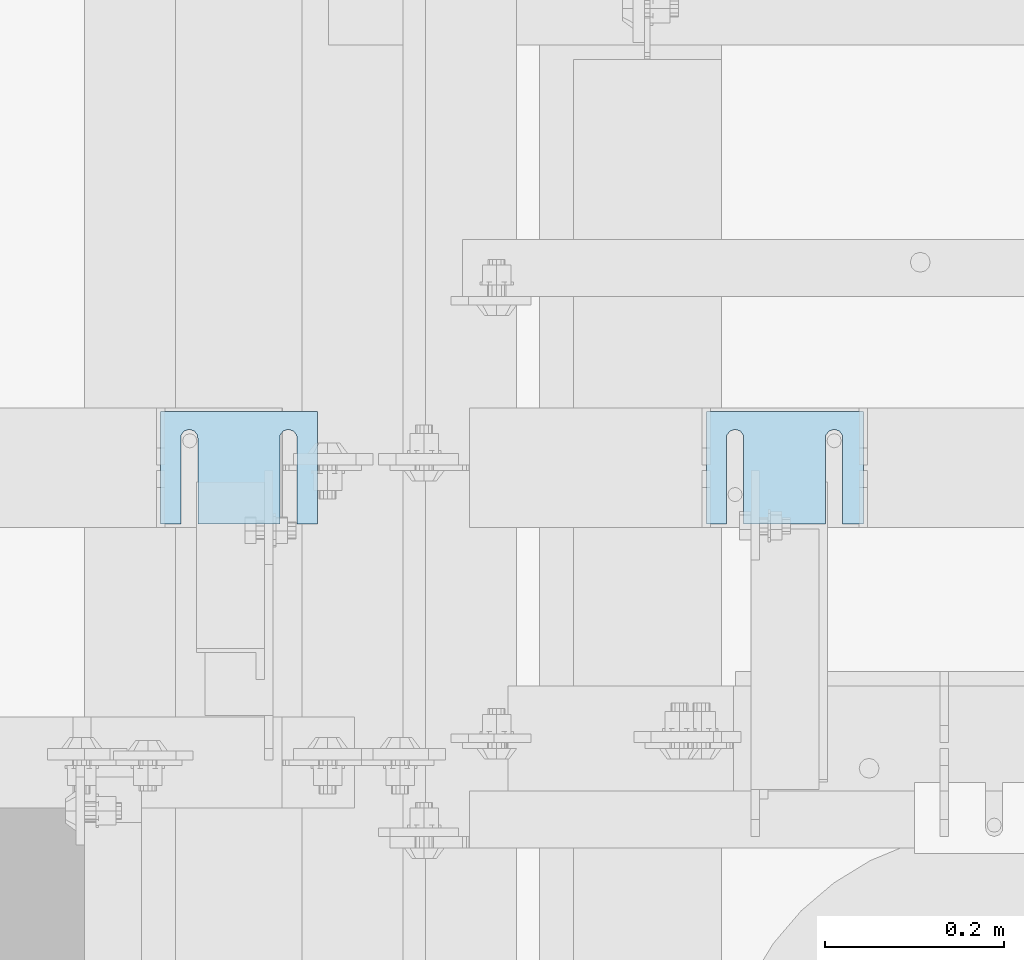
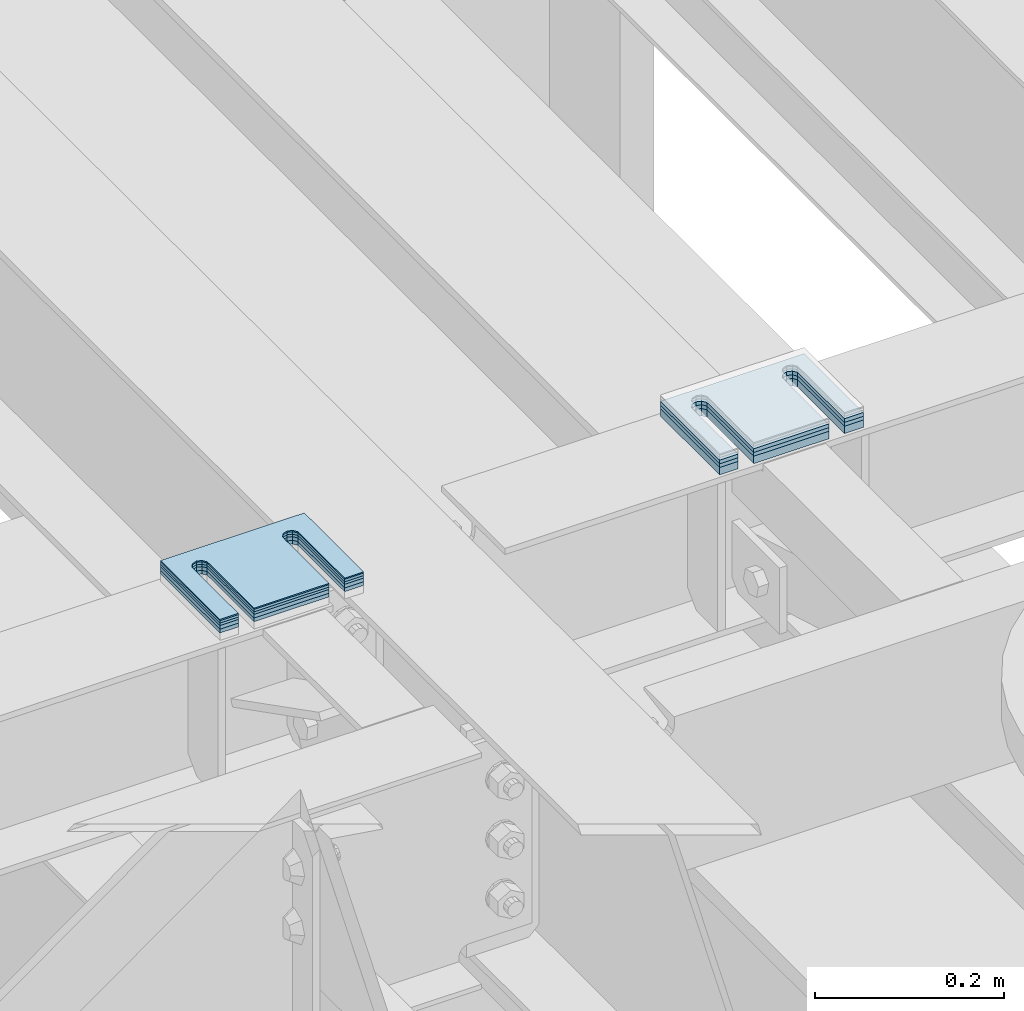
# One storey, part 1611 of 1876: 8 plates, 8 elements without a shape of their own.
"""IFC2X3 building model written with IfcOpenShell, lengths in millimetres."""

import ifcopenshell
import ifcopenshell.guid

model = None  # the IFC model being written
_history = None  # IfcOwnerHistory: only IFC2X3 demands one
_inside = {}  # id of a spatial element -> (the spatial element, [elements in it])
_under = {}  # id of a project, library or spatial element -> (it, [spatial elements below it])
_declared = {}  # id of a project -> (the project, [libraries it declares])
_typed = {}  # id of a type object -> (the type object, [elements of that type])
_made_of = {}  # id of a material, layer set ... -> (it, [elements and type objects made of it])


def new_model(schema):
    """Start an empty IFC model of exactly this schema.

    Asked for "IFC4X3", IfcOpenShell would pick the latest addendum, in which some entities
    have other attributes; the version numbers below select the first issue.
    IFC2X3 requires an IfcOwnerHistory on every rooted entity: one is made here for all.
    """
    global model, _history
    if schema == "IFC4X3":
        model = ifcopenshell.file(schema_version=(4, 3, 0, 0))
    else:
        model = ifcopenshell.file(schema=schema)
    _inside.clear()
    _under.clear()
    _declared.clear()
    _typed.clear()
    _made_of.clear()
    _history = None
    if model.schema == "IFC2X3":
        org = make("IfcOrganization", Name="unknown")
        user = make(
            "IfcPersonAndOrganization",
            ThePerson=make("IfcPerson", FamilyName="unknown"),
            TheOrganization=org,
        )
        app = make(
            "IfcApplication",
            ApplicationDeveloper=org,
            Version="unknown",
            ApplicationFullName="unknown",
            ApplicationIdentifier="unknown",
        )
        _history = make(
            "IfcOwnerHistory",
            OwningUser=user,
            OwningApplication=app,
            ChangeAction="ADDED",
            CreationDate=0,
        )
    return model


def make(cls, **values):
    """One entity of the class cls with the attributes given. An attribute that is None is left unset."""
    return model.create_entity(
        cls, **{name: value for name, value in values.items() if value is not None}
    )


def rooted(cls, **values):
    """An entity with a GlobalId (a new one), such as an element, a storey or a relation."""
    return make(cls, GlobalId=ifcopenshell.guid.new(), OwnerHistory=_history, **values)


def si_unit(unit_type, name, prefix=None):
    """IfcSIUnit, for example si_unit("LENGTHUNIT", "METRE", prefix="MILLI")."""
    return make("IfcSIUnit", UnitType=unit_type, Prefix=prefix, Name=name)


def assignment(units):
    """IfcUnitAssignment: the units of a project."""
    return None if units is None else make("IfcUnitAssignment", Units=units)


def point(xyz):
    """IfcCartesianPoint."""
    return None if xyz is None else make("IfcCartesianPoint", Coordinates=xyz)


def direction(xyz):
    """IfcDirection."""
    return None if xyz is None else make("IfcDirection", DirectionRatios=xyz)


def frame(location, z_axis=None, x_axis=None):
    """IfcAxis2Placement3D, a coordinate frame: its origin and axes. An axis left out is left unset."""
    return make(
        "IfcAxis2Placement3D",
        Location=point(location),
        Axis=direction(z_axis),
        RefDirection=direction(x_axis),
    )


def origin_with_axes():
    """The frame at (0, 0, 0) with the z axis (0, 0, 1) and the x axis (1, 0, 0) written out."""
    return frame((0.0, 0.0, 0.0), z_axis=(0.0, 0.0, 1.0), x_axis=(1.0, 0.0, 0.0))


def place(relative_to, where):
    """IfcLocalPlacement: puts the frame where relative to a parent placement (None: the world)."""
    return make(
        "IfcLocalPlacement", PlacementRelTo=relative_to, RelativePlacement=where
    )


def context(
    kind, dimensions, precision=None, world=None, true_north=None, identifier=None
):
    """IfcGeometricRepresentationContext, for example the 3D "Model" context."""
    return make(
        "IfcGeometricRepresentationContext",
        ContextIdentifier=identifier,
        ContextType=kind,
        CoordinateSpaceDimension=dimensions,
        Precision=precision,
        WorldCoordinateSystem=world,
        TrueNorth=true_north,
    )


def subcontext(parent, identifier, kind, view, scale=None):
    """IfcGeometricRepresentationSubContext, for example "Body" below "Model"."""
    return make(
        "IfcGeometricRepresentationSubContext",
        ContextIdentifier=identifier,
        ContextType=kind,
        ParentContext=parent,
        TargetScale=scale,
        TargetView=view,
    )


def project(units=None, contexts=None):
    """IfcProject with its units and contexts."""
    return rooted(
        "IfcProject",
        Name="project",
        RepresentationContexts=contexts,
        UnitsInContext=assignment(units),
    )


def spatial(cls, under=None, at=None, **own):
    """A site, building, storey or space (cls), placed at a placement, below another one or the project."""
    s = rooted(cls, ObjectPlacement=at, **own)
    if under is not None:
        _under.setdefault(under.id(), (under, []))[1].append(s)
    return s


def faces_of(points, faces, orient=None, outer=None):
    """IfcFace entities. A face is a list of loops; a loop is a list of indices into points, from 0.

    orient and outer hold one flag for each loop. By default every Orientation is true, the
    first loop of a face is its IfcFaceOuterBound and the others are IfcFaceBound.
    """
    made = []
    for i, loops in enumerate(faces):
        bounds = []
        for j, loop in enumerate(loops):
            is_outer = j == 0 if outer is None else outer[i][j]
            bounds.append(
                make(
                    "IfcFaceOuterBound" if is_outer else "IfcFaceBound",
                    Bound=make("IfcPolyLoop", Polygon=[points[k] for k in loop]),
                    Orientation=True if orient is None else orient[i][j],
                )
            )
        made.append(make("IfcFace", Bounds=bounds))
    return made


def faceted_brep(points, faces, orient=None, outer=None, voids=None):
    """IfcFacetedBrep: a solid bounded by flat faces; with voids (closed shells), ...WithVoids."""
    shared = [point(p) for p in points]
    hull = make("IfcClosedShell", CfsFaces=faces_of(shared, faces, orient, outer))
    if voids is None:
        return make("IfcFacetedBrep", Outer=hull)
    return make(
        "IfcFacetedBrepWithVoids",
        Outer=hull,
        Voids=[
            make(cls, CfsFaces=faces_of(shared, fs, o, b)) for cls, fs, o, b in voids
        ],
    )


def shape(context_of_items, identifier, shape_type, items):
    """IfcShapeRepresentation: the items that make up one representation, for example the "Body"."""
    return make(
        "IfcShapeRepresentation",
        ContextOfItems=context_of_items,
        RepresentationIdentifier=identifier,
        RepresentationType=shape_type,
        Items=items,
    )


def material(Name=None, Category=None):
    """IfcMaterial."""
    return make("IfcMaterial", Name=Name, Category=Category)


def made_of(thing, what):
    """Note that an element or type object is made of a material, layer set ...; save() writes the relation."""
    if what is not None:
        _made_of.setdefault(what.id(), (what, []))[1].append(thing)
    return thing


def type_object(cls, material=None, **own):
    """A type object (cls), such as IfcWallType, which elements share."""
    return made_of(rooted(cls, **own), material)


def element(
    cls,
    number,
    at=None,
    inside=None,
    cuts=None,
    type_object=None,
    material=None,
    context=None,
    identifier="Body",
    shape_type=None,
    held_by="IfcProductDefinitionShape",
    body=None,
    shapes=None,
    **own,
):
    """One element of the class cls, such as IfcWall. Its Tag is "e" and its number.

    at: its placement. inside: the storey or other place that contains it. cuts: it is an
    opening in that element (IfcRelVoidsElement). A single representation is given by context,
    identifier, shape_type and body (its items); several are given by shapes. held_by: the class
    of the entity that holds the representations. save() writes the other relations.
    """
    e = rooted(cls, Tag="e%d" % number, ObjectPlacement=at, **own)
    if body is not None:
        shapes = [shape(context, identifier, shape_type, body)]
    if shapes is not None:
        e.Representation = make(held_by, Representations=shapes)
    if inside is not None:
        _inside.setdefault(inside.id(), (inside, []))[1].append(e)
    if cuts is not None:
        rooted(
            "IfcRelVoidsElement", RelatingBuildingElement=cuts, RelatedOpeningElement=e
        )
    if type_object is not None:
        _typed.setdefault(type_object.id(), (type_object, []))[1].append(e)
    return made_of(e, material)


def aggregate(whole, parts):
    """IfcRelAggregates: a whole, such as a stair, and the parts it consists of."""
    return rooted("IfcRelAggregates", RelatingObject=whole, RelatedObjects=parts)


def save(model, path):
    """Write the relations noted so far, then the file.

    IfcRelAggregates (storeys below a building ...), IfcRelContainedInSpatialStructure (elements
    in a storey), IfcRelDefinesByType, IfcRelAssociatesMaterial and IfcRelDeclares: one each for
    every whole, place, type object, material and project.
    """
    for whole, parts in _under.values():
        aggregate(whole, parts)
    for where, things in _inside.values():
        rooted(
            "IfcRelContainedInSpatialStructure",
            RelatedElements=things,
            RelatingStructure=where,
        )
    for kind, things in _typed.values():
        rooted("IfcRelDefinesByType", RelatedObjects=things, RelatingType=kind)
    for what, things in _made_of.values():
        rooted("IfcRelAssociatesMaterial", RelatedObjects=things, RelatingMaterial=what)
    for by, libraries in _declared.values():
        rooted("IfcRelDeclares", RelatingContext=by, RelatedDefinitions=libraries)
    model.write(path)


model = new_model("IFC2X3")

# Units and contexts
model_context = context("Model", 3, precision=1e-05, world=origin_with_axes())
body_context = subcontext(model_context, "Body", "Model", "MODEL_VIEW")
ifc_project = project(units=[si_unit("LENGTHUNIT", "METRE", prefix="MILLI"), si_unit("AREAUNIT", "SQUARE_METRE"), si_unit("VOLUMEUNIT", "CUBIC_METRE"), si_unit("MASSUNIT", "GRAM", prefix="KILO"), si_unit("TIMEUNIT", "SECOND"), si_unit("PLANEANGLEUNIT", "RADIAN"), si_unit("SOLIDANGLEUNIT", "STERADIAN"), si_unit("THERMODYNAMICTEMPERATUREUNIT", "DEGREE_CELSIUS"), si_unit("LUMINOUSINTENSITYUNIT", "LUMEN")], contexts=[model_context])

# Site, building, storey
site_placement = place(None, origin_with_axes())
site = spatial("IfcSite", under=ifc_project, at=site_placement, CompositionType="ELEMENT")
building_placement = place(site_placement, origin_with_axes())
building = spatial("IfcBuilding", under=site, at=building_placement, Name="Undefined", CompositionType="ELEMENT")
storey_placement = place(building_placement, origin_with_axes())
storey = spatial("IfcBuildingStorey", under=building, at=storey_placement, Name="Undefined", CompositionType="ELEMENT", Elevation=0.0)

# Assembly, plate
assembly_1_placement = place(storey_placement, origin_with_axes())
assembly_1 = element("IfcElementAssembly", 1, at=assembly_1_placement, inside=storey, Name="SHIM PLATE", AssemblyPlace="NOTDEFINED", PredefinedType="RIGID_FRAME")
ifc_material = material(Name="STEEL/A36")
plate_type_1 = type_object("IfcPlateType", PredefinedType="NOTDEFINED")
plate_1_placement = place(assembly_1_placement, frame((1733.54893551387, 3592.49779911282, 18009.3925), z_axis=(0.0, -1.0, 0.0), x_axis=(-1.0, 0.0, 0.0)))
plate_1 = element("IfcPlate", 2, at=plate_1_placement, type_object=plate_type_1, material=ifc_material, Name="SHIM PLATE", context=body_context, shape_type="Brep", body=[
    faceted_brep([(133.797984932592, -0.793499999999767, 125.39846801759), (133.799788185712, -0.793499999999767, 32.6385373098888), (133.799788185712, 0.793499999999767, 32.6385373098888), (133.797984932592, 0.793499999999767, 125.39846801759), (133.95251601168, -0.793499999999767, 26.6039999741197), (133.95251601168, 0.793499999999767, 26.6039999741197), (137.574395327988, -0.793499999999767, 21.7748223149583), (137.574395327988, 0.793499999999767, 21.7748223149583), (143.324785467194, -0.793499999999767, 19.9385271609622), (143.324785467194, 0.793499999999767, 19.9385271609622), (149.075176282759, -0.793499999999767, 21.7748201969102), (149.075176282759, 0.793499999999767, 21.7748201969102), (152.697057377795, -0.793499999999767, 26.6039965220207), (152.697057377795, 0.793499999999767, 26.6039965220207), (152.84978742646, -0.793499999999767, 32.6385338015343), (152.84978742646, 0.793499999999767, 32.6385338015343), (152.847984173361, -0.793499999999767, 125.398468017593), (152.847984173361, 0.793499999999767, 125.398468017593), (42.2236708188493, -0.793499999999767, 125.398468017582), (42.2236708188493, 0.793499999999767, 125.398468017582), (42.2254740719682, 0.793499999999767, 32.6385328059155), (42.2254740719682, -0.793499999999767, 32.6385328059155), (42.0727440233031, 0.793499999999767, 26.6039955264014), (42.0727440233031, -0.793499999999767, 26.6039955264014), (38.4508629282668, 0.793499999999767, 21.7748192012914), (38.4508629282668, -0.793499999999767, 21.7748192012914), (32.7004721127014, 0.793499999999767, 19.9385261653433), (32.7004721127014, -0.793499999999767, 19.9385261653433), (26.9500819734958, 0.793499999999767, 21.7748213193395), (26.9500819734958, -0.793499999999767, 21.7748213193395), (23.3282026571874, 0.793499999999767, 26.6039989785008), (23.3282026571874, -0.793499999999767, 26.6039989785008), (23.1754748312196, 0.793499999999767, 32.6385363142699), (23.1754748312196, -0.793499999999767, 32.6385363142699), (23.1736715780803, -0.793499999999767, 125.39846801758), (23.1736715780803, 0.793499999999767, 125.39846801758), (1.96488858819066e-05, 0.793499999999767, 125.398468017578), (1.96488858819066e-05, -0.793499999999767, 125.398468017578), (9.09494701772928e-13, -0.793499999999767, 0.0), (9.09494701772928e-13, 0.793499999999767, 0.0), (175.397720336914, -0.793499999999767, 7.27595761418343e-12), (175.397720336914, 0.793499999999767, 7.27595761418343e-12), (175.397735595691, -0.793499999999767, 125.398468017594), (175.397735595691, 0.793499999999767, 125.398468017594)], [[[0, 1, 2, 3]], [[4, 5, 2, 1]], [[6, 7, 5, 4]], [[8, 9, 7, 6]], [[10, 11, 9, 8]], [[12, 13, 11, 10]], [[14, 15, 13, 12]], [[16, 17, 15, 14]], [[18, 19, 20, 21]], [[21, 20, 22, 23]], [[23, 22, 24, 25]], [[25, 24, 26, 27]], [[27, 26, 28, 29]], [[29, 28, 30, 31]], [[31, 30, 32, 33]], [[34, 33, 32, 35]], [[36, 37, 34, 35]], [[38, 37, 36, 39]], [[40, 38, 39, 41]], [[42, 40, 41, 43]], [[12, 10, 8, 6, 4, 1, 0, 18, 21, 23, 25, 27, 29, 31, 33, 34, 37, 38, 40, 42, 16, 14]], [[19, 18, 0, 3]], [[43, 41, 39, 36, 35, 32, 30, 28, 26, 24, 22, 20, 19, 3, 2, 5, 7, 9, 11, 13, 15, 17]], [[42, 43, 17, 16]]]),
])
aggregate(assembly_1, [plate_1])

assembly_2_placement = place(storey_placement, origin_with_axes())
assembly_2 = element("IfcElementAssembly", 3, at=assembly_2_placement, inside=storey, Name="SHIM PLATE", AssemblyPlace="NOTDEFINED", PredefinedType="RIGID_FRAME")
plate_type_2 = type_object("IfcPlateType", PredefinedType="NOTDEFINED")
plate_2_placement = place(assembly_2_placement, frame((1733.54893551387, 3592.4977991129, 18007.0115), z_axis=(0.0, -1.0, 0.0), x_axis=(-1.0, 0.0, 0.0)))
plate_2 = element("IfcPlate", 4, at=plate_2_placement, type_object=plate_type_2, material=ifc_material, Name="SHIM PLATE", context=body_context, shape_type="Brep", body=[
    faceted_brep([(133.797984932592, -1.58750000000146, 125.39846801759), (133.799788185712, -1.58750000000146, 32.6385373098888), (133.799788185712, 1.58750000000146, 32.6385373098888), (133.797984932592, 1.58750000000146, 125.39846801759), (133.95251601168, -1.58750000000146, 26.6039999741197), (133.95251601168, 1.58750000000146, 26.6039999741197), (137.574395327988, -1.58750000000146, 21.7748223149583), (137.574395327988, 1.58750000000146, 21.7748223149583), (143.324785467194, -1.58750000000146, 19.9385271609622), (143.324785467194, 1.58750000000146, 19.9385271609622), (149.075176282759, -1.58750000000146, 21.7748201969102), (149.075176282759, 1.58750000000146, 21.7748201969102), (152.697057377795, -1.58750000000146, 26.6039965220207), (152.697057377795, 1.58750000000146, 26.6039965220207), (152.84978742646, -1.58750000000146, 32.6385338015343), (152.84978742646, 1.58750000000146, 32.6385338015343), (152.847984173361, -1.58750000000146, 125.398468017593), (152.847984173361, 1.58750000000146, 125.398468017593), (42.2236708188493, -1.58750000000146, 125.398468017582), (42.2236708188493, 1.58750000000146, 125.398468017582), (42.2254740719682, 1.58750000000146, 32.6385328059155), (42.2254740719682, -1.58750000000146, 32.6385328059155), (42.0727440233031, 1.58750000000146, 26.6039955264014), (42.0727440233031, -1.58750000000146, 26.6039955264014), (38.4508629282668, 1.58750000000146, 21.7748192012914), (38.4508629282668, -1.58750000000146, 21.7748192012914), (32.7004721127014, 1.58750000000146, 19.9385261653433), (32.7004721127014, -1.58750000000146, 19.9385261653433), (26.9500819734958, 1.58750000000146, 21.7748213193395), (26.9500819734958, -1.58750000000146, 21.7748213193395), (23.3282026571874, 1.58750000000146, 26.6039989785008), (23.3282026571874, -1.58750000000146, 26.6039989785008), (23.1754748312196, 1.58750000000146, 32.6385363142699), (23.1754748312196, -1.58750000000146, 32.6385363142699), (23.1736715780803, -1.58750000000146, 125.39846801758), (23.1736715780803, 1.58750000000146, 125.39846801758), (1.96491696442536e-05, 1.58750000000146, 125.398468017578), (1.96491696442536e-05, -1.58750000000146, 125.398468017578), (9.09494701772928e-13, -1.58750000000146, 4.54747350886464e-13), (9.09494701772928e-13, 1.58750000000146, 4.54747350886464e-13), (175.397720336914, -1.58750000000146, 7.27595761418343e-12), (175.397720336914, 1.58750000000146, 7.27595761418343e-12), (175.397735595691, -1.58750000000146, 125.398468017594), (175.397735595691, 1.58750000000146, 125.398468017594)], [[[0, 1, 2, 3]], [[4, 5, 2, 1]], [[6, 7, 5, 4]], [[8, 9, 7, 6]], [[10, 11, 9, 8]], [[12, 13, 11, 10]], [[14, 15, 13, 12]], [[16, 17, 15, 14]], [[18, 19, 20, 21]], [[21, 20, 22, 23]], [[23, 22, 24, 25]], [[25, 24, 26, 27]], [[27, 26, 28, 29]], [[29, 28, 30, 31]], [[31, 30, 32, 33]], [[34, 33, 32, 35]], [[36, 37, 34, 35]], [[38, 37, 36, 39]], [[40, 38, 39, 41]], [[42, 40, 41, 43]], [[12, 10, 8, 6, 4, 1, 0, 18, 21, 23, 25, 27, 29, 31, 33, 34, 37, 38, 40, 42, 16, 14]], [[19, 18, 0, 3]], [[43, 41, 39, 36, 35, 32, 30, 28, 26, 24, 22, 20, 19, 3, 2, 5, 7, 9, 11, 13, 15, 17]], [[42, 43, 17, 16]]]),
])
aggregate(assembly_2, [plate_2])

assembly_3_placement = place(storey_placement, origin_with_axes())
assembly_3 = element("IfcElementAssembly", 5, at=assembly_3_placement, inside=storey, Name="SHIM PLATE", AssemblyPlace="NOTDEFINED", PredefinedType="RIGID_FRAME")
plate_3_placement = place(assembly_3_placement, frame((1733.54893551387, 3592.49779911298, 18003.8365), z_axis=(0.0, -1.0, 0.0), x_axis=(-1.0, 0.0, 0.0)))
plate_3 = element("IfcPlate", 6, at=plate_3_placement, type_object=plate_type_2, material=ifc_material, Name="SHIM PLATE", context=body_context, shape_type="Brep", body=[
    faceted_brep([(133.797984932592, -1.58750000000146, 125.39846801759), (133.799788185712, -1.58750000000146, 32.6385373098888), (133.799788185712, 1.58750000000146, 32.6385373098888), (133.797984932592, 1.58750000000146, 125.39846801759), (133.95251601168, -1.58750000000146, 26.6039999741197), (133.95251601168, 1.58750000000146, 26.6039999741197), (137.574395327988, -1.58750000000146, 21.7748223149583), (137.574395327988, 1.58750000000146, 21.7748223149583), (143.324785467194, -1.58750000000146, 19.9385271609622), (143.324785467194, 1.58750000000146, 19.9385271609622), (149.075176282759, -1.58750000000146, 21.7748201969102), (149.075176282759, 1.58750000000146, 21.7748201969102), (152.697057377795, -1.58750000000146, 26.6039965220207), (152.697057377795, 1.58750000000146, 26.6039965220207), (152.84978742646, -1.58750000000146, 32.6385338015343), (152.84978742646, 1.58750000000146, 32.6385338015343), (152.847984173361, -1.58750000000146, 125.398468017593), (152.847984173361, 1.58750000000146, 125.398468017593), (42.2236708188493, -1.58750000000146, 125.398468017582), (42.2236708188493, 1.58750000000146, 125.398468017582), (42.2254740719682, 1.58750000000146, 32.6385328059155), (42.2254740719682, -1.58750000000146, 32.6385328059155), (42.0727440233031, 1.58750000000146, 26.6039955264014), (42.0727440233031, -1.58750000000146, 26.6039955264014), (38.4508629282668, 1.58750000000146, 21.7748192012914), (38.4508629282668, -1.58750000000146, 21.7748192012914), (32.7004721127014, 1.58750000000146, 19.9385261653433), (32.7004721127014, -1.58750000000146, 19.9385261653433), (26.9500819734958, 1.58750000000146, 21.7748213193395), (26.9500819734958, -1.58750000000146, 21.7748213193395), (23.3282026571874, 1.58750000000146, 26.6039989785008), (23.3282026571874, -1.58750000000146, 26.6039989785008), (23.1754748312196, 1.58750000000146, 32.6385363142699), (23.1754748312196, -1.58750000000146, 32.6385363142699), (23.1736715780803, -1.58750000000146, 125.39846801758), (23.1736715780803, 1.58750000000146, 125.39846801758), (1.96491696442536e-05, 1.58750000000146, 125.398468017578), (1.96491696442536e-05, -1.58750000000146, 125.398468017578), (9.09494701772928e-13, -1.58750000000146, 4.54747350886464e-13), (9.09494701772928e-13, 1.58750000000146, 4.54747350886464e-13), (175.397720336914, -1.58750000000146, 7.27595761418343e-12), (175.397720336914, 1.58750000000146, 7.27595761418343e-12), (175.397735595691, -1.58750000000146, 125.398468017594), (175.397735595691, 1.58750000000146, 125.398468017594)], [[[0, 1, 2, 3]], [[4, 5, 2, 1]], [[6, 7, 5, 4]], [[8, 9, 7, 6]], [[10, 11, 9, 8]], [[12, 13, 11, 10]], [[14, 15, 13, 12]], [[16, 17, 15, 14]], [[18, 19, 20, 21]], [[21, 20, 22, 23]], [[23, 22, 24, 25]], [[25, 24, 26, 27]], [[27, 26, 28, 29]], [[29, 28, 30, 31]], [[31, 30, 32, 33]], [[34, 33, 32, 35]], [[36, 37, 34, 35]], [[38, 37, 36, 39]], [[40, 38, 39, 41]], [[42, 40, 41, 43]], [[12, 10, 8, 6, 4, 1, 0, 18, 21, 23, 25, 27, 29, 31, 33, 34, 37, 38, 40, 42, 16, 14]], [[19, 18, 0, 3]], [[43, 41, 39, 36, 35, 32, 30, 28, 26, 24, 22, 20, 19, 3, 2, 5, 7, 9, 11, 13, 15, 17]], [[42, 43, 17, 16]]]),
])
aggregate(assembly_3, [plate_3])

assembly_4_placement = place(storey_placement, origin_with_axes())
assembly_4 = element("IfcElementAssembly", 7, at=assembly_4_placement, inside=storey, Name="SHIM PLATE", AssemblyPlace="NOTDEFINED", PredefinedType="RIGID_FRAME")
plate_type_3 = type_object("IfcPlateType", PredefinedType="NOTDEFINED")
plate_4_placement = place(assembly_4_placement, frame((2343.14900265254, 3592.49779911306, 17999.868), z_axis=(0.0, -1.0, 0.0), x_axis=(-1.0, 0.0, 0.0)))
plate_4 = element("IfcPlate", 8, at=plate_4_placement, type_object=plate_type_3, material=ifc_material, Name="SHIM PLATE", context=body_context, shape_type="Brep", body=[
    faceted_brep([(133.797984932592, -2.38100000000122, 125.39846801759), (133.799788185712, -2.38100000000122, 32.6385373098888), (133.799788185712, 2.38100000000122, 32.6385373098888), (133.797984932592, 2.38100000000122, 125.39846801759), (133.95251601168, -2.38100000000122, 26.6039999741197), (133.95251601168, 2.38100000000122, 26.6039999741197), (137.574395327988, -2.38100000000122, 21.7748223149583), (137.574395327988, 2.38100000000122, 21.7748223149583), (143.324785467194, -2.38100000000122, 19.9385271609622), (143.324785467194, 2.38100000000122, 19.9385271609622), (149.075176282759, -2.38100000000122, 21.7748201969102), (149.075176282759, 2.38100000000122, 21.7748201969102), (152.697057377795, -2.38100000000122, 26.6039965220207), (152.697057377795, 2.38100000000122, 26.6039965220207), (152.84978742646, -2.38100000000122, 32.6385338015343), (152.84978742646, 2.38100000000122, 32.6385338015343), (152.847984173361, -2.38100000000122, 125.398468017593), (152.847984173361, 2.38100000000122, 125.398468017593), (42.2236708188493, -2.38100000000122, 125.398468017582), (42.2236708188493, 2.38100000000122, 125.398468017582), (42.2254740719682, 2.38100000000122, 32.6385328059155), (42.2254740719682, -2.38100000000122, 32.6385328059155), (42.0727440233031, 2.38100000000122, 26.6039955264014), (42.0727440233031, -2.38100000000122, 26.6039955264014), (38.4508629282668, 2.38100000000122, 21.7748192012914), (38.4508629282668, -2.38100000000122, 21.7748192012914), (32.7004721127014, 2.38100000000122, 19.9385261653433), (32.7004721127014, -2.38100000000122, 19.9385261653433), (26.9500819734958, 2.38100000000122, 21.7748213193395), (26.9500819734958, -2.38100000000122, 21.7748213193395), (23.3282026571874, 2.38100000000122, 26.6039989785008), (23.3282026571874, -2.38100000000122, 26.6039989785008), (23.1754748312196, 2.38100000000122, 32.6385363142699), (23.1754748312196, -2.38100000000122, 32.6385363142699), (23.1736715780803, -2.38100000000122, 125.39846801758), (23.1736715780803, 2.38100000000122, 125.39846801758), (1.96494534066005e-05, 2.38100000000122, 125.398468017578), (1.96494534066005e-05, -2.38100000000122, 125.398468017578), (0.0, -2.38100000000122, 4.54747350886464e-13), (0.0, 2.38100000000122, 4.54747350886464e-13), (175.397720336914, -2.38100000000122, 7.27595761418343e-12), (175.397720336914, 2.38100000000122, 7.27595761418343e-12), (175.397735595691, -2.38100000000122, 125.398468017594), (175.397735595691, 2.38100000000122, 125.398468017594)], [[[0, 1, 2, 3]], [[4, 5, 2, 1]], [[6, 7, 5, 4]], [[8, 9, 7, 6]], [[10, 11, 9, 8]], [[12, 13, 11, 10]], [[14, 15, 13, 12]], [[16, 17, 15, 14]], [[18, 19, 20, 21]], [[21, 20, 22, 23]], [[23, 22, 24, 25]], [[25, 24, 26, 27]], [[27, 26, 28, 29]], [[29, 28, 30, 31]], [[31, 30, 32, 33]], [[34, 33, 32, 35]], [[36, 37, 34, 35]], [[38, 37, 36, 39]], [[40, 38, 39, 41]], [[42, 40, 41, 43]], [[12, 10, 8, 6, 4, 1, 0, 18, 21, 23, 25, 27, 29, 31, 33, 34, 37, 38, 40, 42, 16, 14]], [[19, 18, 0, 3]], [[43, 41, 39, 36, 35, 32, 30, 28, 26, 24, 22, 20, 19, 3, 2, 5, 7, 9, 11, 13, 15, 17]], [[42, 43, 17, 16]]]),
])
aggregate(assembly_4, [plate_4])

assembly_5_placement = place(storey_placement, origin_with_axes())
assembly_5 = element("IfcElementAssembly", 9, at=assembly_5_placement, inside=storey, Name="SHIM PLATE", AssemblyPlace="NOTDEFINED", PredefinedType="RIGID_FRAME")
plate_5_placement = place(assembly_5_placement, frame((2343.14900265254, 3592.49779911314, 17995.106), z_axis=(0.0, -1.0, 0.0), x_axis=(-1.0, 0.0, 0.0)))
plate_5 = element("IfcPlate", 10, at=plate_5_placement, type_object=plate_type_3, material=ifc_material, Name="SHIM PLATE", context=body_context, shape_type="Brep", body=[
    faceted_brep([(133.797984932592, -2.38100000000122, 125.39846801759), (133.799788185712, -2.38100000000122, 32.6385373098888), (133.799788185712, 2.38100000000122, 32.6385373098888), (133.797984932592, 2.38100000000122, 125.39846801759), (133.95251601168, -2.38100000000122, 26.6039999741197), (133.95251601168, 2.38100000000122, 26.6039999741197), (137.574395327988, -2.38100000000122, 21.7748223149583), (137.574395327988, 2.38100000000122, 21.7748223149583), (143.324785467194, -2.38100000000122, 19.9385271609622), (143.324785467194, 2.38100000000122, 19.9385271609622), (149.075176282759, -2.38100000000122, 21.7748201969102), (149.075176282759, 2.38100000000122, 21.7748201969102), (152.697057377795, -2.38100000000122, 26.6039965220207), (152.697057377795, 2.38100000000122, 26.6039965220207), (152.84978742646, -2.38100000000122, 32.6385338015343), (152.84978742646, 2.38100000000122, 32.6385338015343), (152.847984173361, -2.38100000000122, 125.398468017593), (152.847984173361, 2.38100000000122, 125.398468017593), (42.2236708188493, -2.38100000000122, 125.398468017582), (42.2236708188493, 2.38100000000122, 125.398468017582), (42.2254740719682, 2.38100000000122, 32.6385328059155), (42.2254740719682, -2.38100000000122, 32.6385328059155), (42.0727440233031, 2.38100000000122, 26.6039955264014), (42.0727440233031, -2.38100000000122, 26.6039955264014), (38.4508629282668, 2.38100000000122, 21.7748192012914), (38.4508629282668, -2.38100000000122, 21.7748192012914), (32.7004721127014, 2.38100000000122, 19.9385261653433), (32.7004721127014, -2.38100000000122, 19.9385261653433), (26.9500819734958, 2.38100000000122, 21.7748213193395), (26.9500819734958, -2.38100000000122, 21.7748213193395), (23.3282026571874, 2.38100000000122, 26.6039989785008), (23.3282026571874, -2.38100000000122, 26.6039989785008), (23.1754748312196, 2.38100000000122, 32.6385363142699), (23.1754748312196, -2.38100000000122, 32.6385363142699), (23.1736715780803, -2.38100000000122, 125.39846801758), (23.1736715780803, 2.38100000000122, 125.39846801758), (1.96494534066005e-05, 2.38100000000122, 125.398468017578), (1.96494534066005e-05, -2.38100000000122, 125.398468017578), (0.0, -2.38100000000122, 4.54747350886464e-13), (0.0, 2.38100000000122, 4.54747350886464e-13), (175.397720336914, -2.38100000000122, 7.27595761418343e-12), (175.397720336914, 2.38100000000122, 7.27595761418343e-12), (175.397735595691, -2.38100000000122, 125.398468017594), (175.397735595691, 2.38100000000122, 125.398468017594)], [[[0, 1, 2, 3]], [[4, 5, 2, 1]], [[6, 7, 5, 4]], [[8, 9, 7, 6]], [[10, 11, 9, 8]], [[12, 13, 11, 10]], [[14, 15, 13, 12]], [[16, 17, 15, 14]], [[18, 19, 20, 21]], [[21, 20, 22, 23]], [[23, 22, 24, 25]], [[25, 24, 26, 27]], [[27, 26, 28, 29]], [[29, 28, 30, 31]], [[31, 30, 32, 33]], [[34, 33, 32, 35]], [[36, 37, 34, 35]], [[38, 37, 36, 39]], [[40, 38, 39, 41]], [[42, 40, 41, 43]], [[12, 10, 8, 6, 4, 1, 0, 18, 21, 23, 25, 27, 29, 31, 33, 34, 37, 38, 40, 42, 16, 14]], [[19, 18, 0, 3]], [[43, 41, 39, 36, 35, 32, 30, 28, 26, 24, 22, 20, 19, 3, 2, 5, 7, 9, 11, 13, 15, 17]], [[42, 43, 17, 16]]]),
])
aggregate(assembly_5, [plate_5])

assembly_6_placement = place(storey_placement, origin_with_axes())
assembly_6 = element("IfcElementAssembly", 11, at=assembly_6_placement, inside=storey, Name="SHIM PLATE", AssemblyPlace="NOTDEFINED", PredefinedType="RIGID_FRAME")
plate_6_placement = place(assembly_6_placement, frame((1733.54893551387, 3592.49779911306, 17999.868), z_axis=(0.0, -1.0, 0.0), x_axis=(-1.0, 0.0, 0.0)))
plate_6 = element("IfcPlate", 12, at=plate_6_placement, type_object=plate_type_3, material=ifc_material, Name="SHIM PLATE", context=body_context, shape_type="Brep", body=[
    faceted_brep([(133.797984932592, -2.38100000000122, 125.39846801759), (133.799788185712, -2.38100000000122, 32.6385373098888), (133.799788185712, 2.38100000000122, 32.6385373098888), (133.797984932592, 2.38100000000122, 125.39846801759), (133.95251601168, -2.38100000000122, 26.6039999741197), (133.95251601168, 2.38100000000122, 26.6039999741197), (137.574395327988, -2.38100000000122, 21.7748223149583), (137.574395327988, 2.38100000000122, 21.7748223149583), (143.324785467194, -2.38100000000122, 19.9385271609622), (143.324785467194, 2.38100000000122, 19.9385271609622), (149.075176282759, -2.38100000000122, 21.7748201969102), (149.075176282759, 2.38100000000122, 21.7748201969102), (152.697057377795, -2.38100000000122, 26.6039965220207), (152.697057377795, 2.38100000000122, 26.6039965220207), (152.84978742646, -2.38100000000122, 32.6385338015343), (152.84978742646, 2.38100000000122, 32.6385338015343), (152.847984173361, -2.38100000000122, 125.398468017593), (152.847984173361, 2.38100000000122, 125.398468017593), (42.2236708188493, -2.38100000000122, 125.398468017582), (42.2236708188493, 2.38100000000122, 125.398468017582), (42.2254740719682, 2.38100000000122, 32.6385328059155), (42.2254740719682, -2.38100000000122, 32.6385328059155), (42.0727440233031, 2.38100000000122, 26.6039955264014), (42.0727440233031, -2.38100000000122, 26.6039955264014), (38.4508629282668, 2.38100000000122, 21.7748192012914), (38.4508629282668, -2.38100000000122, 21.7748192012914), (32.7004721127014, 2.38100000000122, 19.9385261653433), (32.7004721127014, -2.38100000000122, 19.9385261653433), (26.9500819734958, 2.38100000000122, 21.7748213193395), (26.9500819734958, -2.38100000000122, 21.7748213193395), (23.3282026571874, 2.38100000000122, 26.6039989785008), (23.3282026571874, -2.38100000000122, 26.6039989785008), (23.1754748312196, 2.38100000000122, 32.6385363142699), (23.1754748312196, -2.38100000000122, 32.6385363142699), (23.1736715780803, -2.38100000000122, 125.39846801758), (23.1736715780803, 2.38100000000122, 125.39846801758), (1.96494534066005e-05, 2.38100000000122, 125.398468017578), (1.96494534066005e-05, -2.38100000000122, 125.398468017578), (0.0, -2.38100000000122, 4.54747350886464e-13), (0.0, 2.38100000000122, 4.54747350886464e-13), (175.397720336914, -2.38100000000122, 7.27595761418343e-12), (175.397720336914, 2.38100000000122, 7.27595761418343e-12), (175.397735595691, -2.38100000000122, 125.398468017594), (175.397735595691, 2.38100000000122, 125.398468017594)], [[[0, 1, 2, 3]], [[4, 5, 2, 1]], [[6, 7, 5, 4]], [[8, 9, 7, 6]], [[10, 11, 9, 8]], [[12, 13, 11, 10]], [[14, 15, 13, 12]], [[16, 17, 15, 14]], [[18, 19, 20, 21]], [[21, 20, 22, 23]], [[23, 22, 24, 25]], [[25, 24, 26, 27]], [[27, 26, 28, 29]], [[29, 28, 30, 31]], [[31, 30, 32, 33]], [[34, 33, 32, 35]], [[36, 37, 34, 35]], [[38, 37, 36, 39]], [[40, 38, 39, 41]], [[42, 40, 41, 43]], [[12, 10, 8, 6, 4, 1, 0, 18, 21, 23, 25, 27, 29, 31, 33, 34, 37, 38, 40, 42, 16, 14]], [[19, 18, 0, 3]], [[43, 41, 39, 36, 35, 32, 30, 28, 26, 24, 22, 20, 19, 3, 2, 5, 7, 9, 11, 13, 15, 17]], [[42, 43, 17, 16]]]),
])
aggregate(assembly_6, [plate_6])

assembly_7_placement = place(storey_placement, origin_with_axes())
assembly_7 = element("IfcElementAssembly", 13, at=assembly_7_placement, inside=storey, Name="SHIM PLATE", AssemblyPlace="NOTDEFINED", PredefinedType="RIGID_FRAME")
plate_7_placement = place(assembly_7_placement, frame((1733.54893551387, 3592.49779911314, 17995.106), z_axis=(0.0, -1.0, 0.0), x_axis=(-1.0, 0.0, 0.0)))
plate_7 = element("IfcPlate", 14, at=plate_7_placement, type_object=plate_type_3, material=ifc_material, Name="SHIM PLATE", context=body_context, shape_type="Brep", body=[
    faceted_brep([(133.797984932592, -2.38100000000122, 125.39846801759), (133.799788185712, -2.38100000000122, 32.6385373098888), (133.799788185712, 2.38100000000122, 32.6385373098888), (133.797984932592, 2.38100000000122, 125.39846801759), (133.95251601168, -2.38100000000122, 26.6039999741197), (133.95251601168, 2.38100000000122, 26.6039999741197), (137.574395327988, -2.38100000000122, 21.7748223149583), (137.574395327988, 2.38100000000122, 21.7748223149583), (143.324785467194, -2.38100000000122, 19.9385271609622), (143.324785467194, 2.38100000000122, 19.9385271609622), (149.075176282759, -2.38100000000122, 21.7748201969102), (149.075176282759, 2.38100000000122, 21.7748201969102), (152.697057377795, -2.38100000000122, 26.6039965220207), (152.697057377795, 2.38100000000122, 26.6039965220207), (152.84978742646, -2.38100000000122, 32.6385338015343), (152.84978742646, 2.38100000000122, 32.6385338015343), (152.847984173361, -2.38100000000122, 125.398468017593), (152.847984173361, 2.38100000000122, 125.398468017593), (42.2236708188493, -2.38100000000122, 125.398468017582), (42.2236708188493, 2.38100000000122, 125.398468017582), (42.2254740719682, 2.38100000000122, 32.6385328059155), (42.2254740719682, -2.38100000000122, 32.6385328059155), (42.0727440233031, 2.38100000000122, 26.6039955264014), (42.0727440233031, -2.38100000000122, 26.6039955264014), (38.4508629282668, 2.38100000000122, 21.7748192012914), (38.4508629282668, -2.38100000000122, 21.7748192012914), (32.7004721127014, 2.38100000000122, 19.9385261653433), (32.7004721127014, -2.38100000000122, 19.9385261653433), (26.9500819734958, 2.38100000000122, 21.7748213193395), (26.9500819734958, -2.38100000000122, 21.7748213193395), (23.3282026571874, 2.38100000000122, 26.6039989785008), (23.3282026571874, -2.38100000000122, 26.6039989785008), (23.1754748312196, 2.38100000000122, 32.6385363142699), (23.1754748312196, -2.38100000000122, 32.6385363142699), (23.1736715780803, -2.38100000000122, 125.39846801758), (23.1736715780803, 2.38100000000122, 125.39846801758), (1.96494534066005e-05, 2.38100000000122, 125.398468017578), (1.96494534066005e-05, -2.38100000000122, 125.398468017578), (0.0, -2.38100000000122, 4.54747350886464e-13), (0.0, 2.38100000000122, 4.54747350886464e-13), (175.397720336914, -2.38100000000122, 7.27595761418343e-12), (175.397720336914, 2.38100000000122, 7.27595761418343e-12), (175.397735595691, -2.38100000000122, 125.398468017594), (175.397735595691, 2.38100000000122, 125.398468017594)], [[[0, 1, 2, 3]], [[4, 5, 2, 1]], [[6, 7, 5, 4]], [[8, 9, 7, 6]], [[10, 11, 9, 8]], [[12, 13, 11, 10]], [[14, 15, 13, 12]], [[16, 17, 15, 14]], [[18, 19, 20, 21]], [[21, 20, 22, 23]], [[23, 22, 24, 25]], [[25, 24, 26, 27]], [[27, 26, 28, 29]], [[29, 28, 30, 31]], [[31, 30, 32, 33]], [[34, 33, 32, 35]], [[36, 37, 34, 35]], [[38, 37, 36, 39]], [[40, 38, 39, 41]], [[42, 40, 41, 43]], [[12, 10, 8, 6, 4, 1, 0, 18, 21, 23, 25, 27, 29, 31, 33, 34, 37, 38, 40, 42, 16, 14]], [[19, 18, 0, 3]], [[43, 41, 39, 36, 35, 32, 30, 28, 26, 24, 22, 20, 19, 3, 2, 5, 7, 9, 11, 13, 15, 17]], [[42, 43, 17, 16]]]),
])
aggregate(assembly_7, [plate_7])

assembly_8_placement = place(storey_placement, origin_with_axes())
assembly_8 = element("IfcElementAssembly", 15, at=assembly_8_placement, inside=storey, Name="SHIM PLATE", AssemblyPlace="NOTDEFINED", PredefinedType="RIGID_FRAME")
plate_type_4 = type_object("IfcPlateType", PredefinedType="NOTDEFINED")
plate_8_placement = place(assembly_8_placement, frame((2343.14900265254, 3592.49779911322, 17987.9625), z_axis=(0.0, -1.0, 0.0), x_axis=(-1.0, 0.0, 0.0)))
plate_8 = element("IfcPlate", 16, at=plate_8_placement, type_object=plate_type_4, material=ifc_material, Name="SHIM PLATE", context=body_context, shape_type="Brep", body=[
    faceted_brep([(133.797984932592, -4.76250000000073, 125.39846801759), (133.799788185712, -4.76250000000073, 32.6385373098888), (133.799788185712, 4.76250000000073, 32.6385373098888), (133.797984932592, 4.76250000000073, 125.39846801759), (133.95251601168, -4.76250000000073, 26.6039999741197), (133.95251601168, 4.76250000000073, 26.6039999741197), (137.574395327988, -4.76250000000073, 21.7748223149583), (137.574395327988, 4.76250000000073, 21.7748223149583), (143.324785467194, -4.76250000000073, 19.9385271609622), (143.324785467194, 4.76250000000073, 19.9385271609622), (149.075176282759, -4.76250000000073, 21.7748201969102), (149.075176282759, 4.76250000000073, 21.7748201969102), (152.697057377795, -4.76250000000073, 26.6039965220207), (152.697057377795, 4.76250000000073, 26.6039965220207), (152.84978742646, -4.76250000000073, 32.6385338015343), (152.84978742646, 4.76250000000073, 32.6385338015343), (152.847984173361, -4.76250000000073, 125.398468017593), (152.847984173361, 4.76250000000073, 125.398468017593), (42.2236708188493, -4.76250000000073, 125.398468017582), (42.2236708188493, 4.76250000000073, 125.398468017582), (42.2254740719682, 4.76250000000073, 32.6385328059155), (42.2254740719682, -4.76250000000073, 32.6385328059155), (42.0727440233031, 4.76250000000073, 26.6039955264014), (42.0727440233031, -4.76250000000073, 26.6039955264014), (38.4508629282668, 4.76250000000073, 21.7748192012914), (38.4508629282668, -4.76250000000073, 21.7748192012914), (32.7004721127014, 4.76250000000073, 19.9385261653433), (32.7004721127014, -4.76250000000073, 19.9385261653433), (26.9500819734958, 4.76250000000073, 21.7748213193395), (26.9500819734958, -4.76250000000073, 21.7748213193395), (23.3282026571874, 4.76250000000073, 26.6039989785008), (23.3282026571874, -4.76250000000073, 26.6039989785008), (23.1754748312196, 4.76250000000073, 32.6385363142699), (23.1754748312196, -4.76250000000073, 32.6385363142699), (23.1736715780803, -4.76250000000073, 125.39846801758), (23.1736715780803, 4.76250000000073, 125.39846801758), (1.96497371689475e-05, 4.76250000000073, 125.398468017578), (1.96497371689475e-05, -4.76250000000073, 125.398468017578), (0.0, -4.76249999999982, 0.0), (0.0, 4.76249999999982, 0.0), (175.397720336914, -4.76250000000073, 7.27595761418343e-12), (175.397720336914, 4.76250000000073, 7.27595761418343e-12), (175.397735595691, -4.76250000000073, 125.398468017594), (175.397735595691, 4.76250000000073, 125.398468017594)], [[[0, 1, 2, 3]], [[4, 5, 2, 1]], [[6, 7, 5, 4]], [[8, 9, 7, 6]], [[10, 11, 9, 8]], [[12, 13, 11, 10]], [[14, 15, 13, 12]], [[16, 17, 15, 14]], [[18, 19, 20, 21]], [[21, 20, 22, 23]], [[23, 22, 24, 25]], [[25, 24, 26, 27]], [[27, 26, 28, 29]], [[29, 28, 30, 31]], [[31, 30, 32, 33]], [[34, 33, 32, 35]], [[36, 37, 34, 35]], [[38, 37, 36, 39]], [[40, 38, 39, 41]], [[42, 40, 41, 43]], [[12, 10, 8, 6, 4, 1, 0, 18, 21, 23, 25, 27, 29, 31, 33, 34, 37, 38, 40, 42, 16, 14]], [[19, 18, 0, 3]], [[43, 41, 39, 36, 35, 32, 30, 28, 26, 24, 22, 20, 19, 3, 2, 5, 7, 9, 11, 13, 15, 17]], [[42, 43, 17, 16]]]),
])
aggregate(assembly_8, [plate_8])

save(model, "model.ifc")
